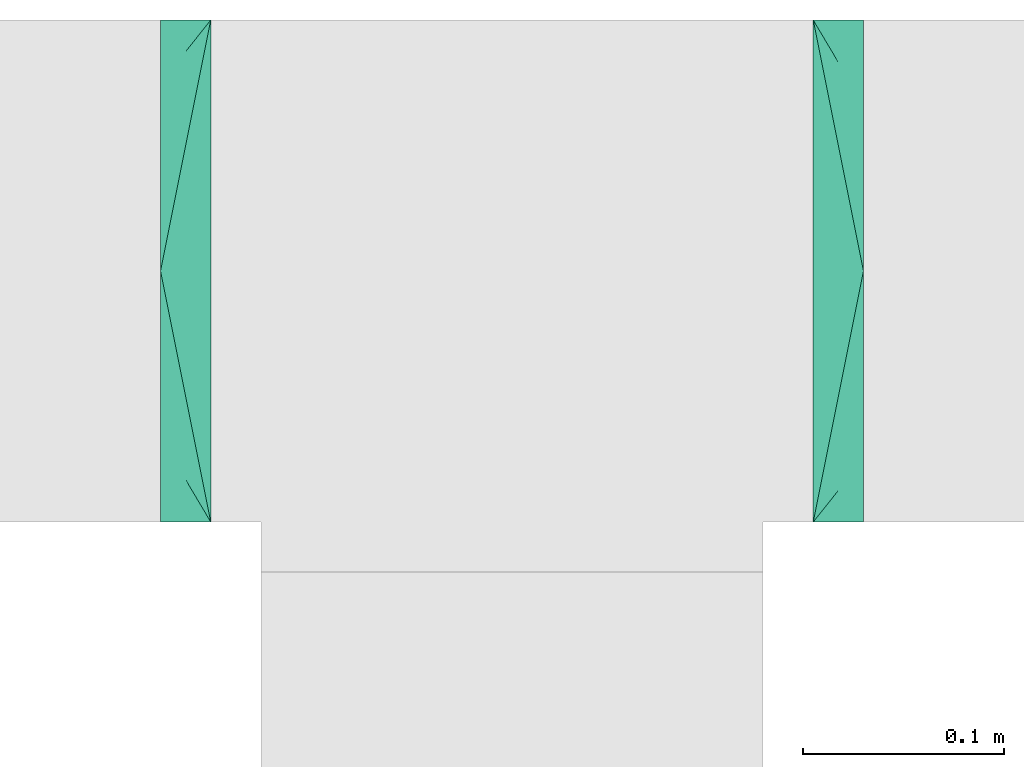
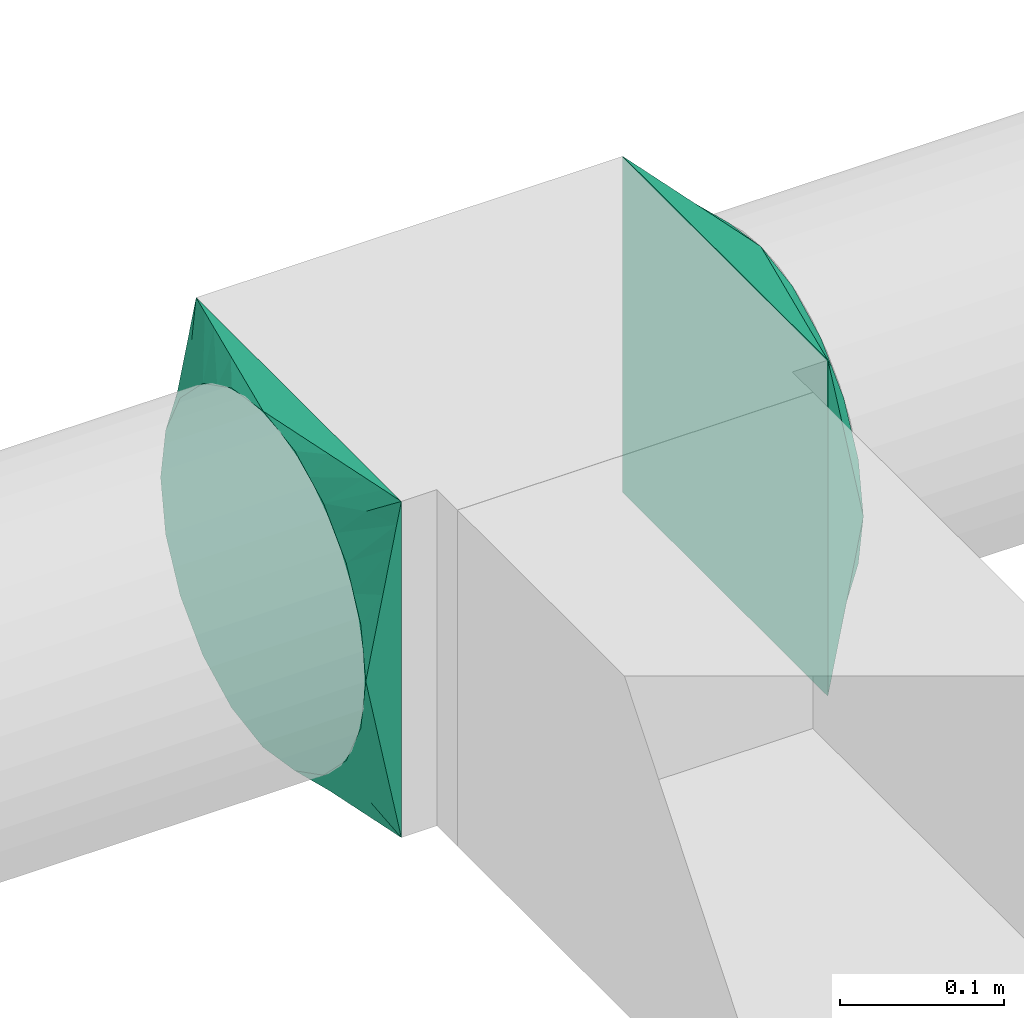
# One storey, part 2 of 3: 2 flow fittings.
"""IFC2X3 building model written with IfcOpenShell, lengths in millimetres."""

from ifc_helpers import new_model, entity, si_unit, converted_unit, derived_unit, direction, frame, origin, place, context, subcontext, project, spatial, faceted_brep, source, transform, mapped, material, type_object, type_shapes, element, save


model = new_model("IFC2X3")

# Units and contexts
model_context = context("Model", 3, precision=0.01, world=origin(), true_north=direction((6.12303176911189e-17, 1.0)))
body_context = subcontext(model_context, "Body", "Model", "MODEL_VIEW")
ifc_project = project(units=[si_unit("LENGTHUNIT", "METRE", prefix="MILLI"), si_unit("AREAUNIT", "SQUARE_METRE"), si_unit("VOLUMEUNIT", "CUBIC_METRE"), converted_unit("PLANEANGLEUNIT", "DEGREE", entity("IfcRatioMeasure", 0.0174532925199433), si_unit("PLANEANGLEUNIT", "RADIAN"), dimensions=[0, 0, 0, 0, 0, 0, 0]), si_unit("MASSUNIT", "GRAM", prefix="KILO"), derived_unit("MASSDENSITYUNIT", [(si_unit("MASSUNIT", "GRAM", prefix="KILO"), 1), (si_unit("LENGTHUNIT", "METRE"), -3)]), si_unit("TIMEUNIT", "SECOND"), si_unit("FREQUENCYUNIT", "HERTZ"), si_unit("THERMODYNAMICTEMPERATUREUNIT", "DEGREE_CELSIUS"), derived_unit("THERMALTRANSMITTANCEUNIT", [(si_unit("MASSUNIT", "GRAM", prefix="KILO"), 1), (si_unit("THERMODYNAMICTEMPERATUREUNIT", "KELVIN"), -1), (si_unit("TIMEUNIT", "SECOND"), -3)]), derived_unit("VOLUMETRICFLOWRATEUNIT", [(si_unit("LENGTHUNIT", "METRE"), 3), (si_unit("TIMEUNIT", "SECOND"), -1)]), si_unit("ELECTRICCURRENTUNIT", "AMPERE"), si_unit("ELECTRICVOLTAGEUNIT", "VOLT"), si_unit("POWERUNIT", "WATT"), si_unit("FORCEUNIT", "NEWTON", prefix="KILO"), si_unit("ILLUMINANCEUNIT", "LUX"), si_unit("LUMINOUSFLUXUNIT", "LUMEN"), si_unit("LUMINOUSINTENSITYUNIT", "CANDELA"), derived_unit("USERDEFINED", [(si_unit("MASSUNIT", "GRAM", prefix="KILO"), -1), (si_unit("LENGTHUNIT", "METRE"), -2), (si_unit("TIMEUNIT", "SECOND"), 3), (si_unit("LUMINOUSFLUXUNIT", "LUMEN"), 1)]), derived_unit("LINEARVELOCITYUNIT", [(si_unit("LENGTHUNIT", "METRE"), 1), (si_unit("TIMEUNIT", "SECOND"), -1)]), si_unit("PRESSUREUNIT", "PASCAL"), derived_unit("USERDEFINED", [(si_unit("LENGTHUNIT", "METRE"), -2), (si_unit("MASSUNIT", "GRAM", prefix="KILO"), 1), (si_unit("TIMEUNIT", "SECOND"), -2)])], contexts=[model_context])

# Site, building, storey
site_placement = place(None, origin())
site = spatial("IfcSite", under=ifc_project, at=site_placement, CompositionType="ELEMENT")
building_placement = place(site_placement, origin())
building = spatial("IfcBuilding", under=site, at=building_placement, CompositionType="ELEMENT")
storey_placement = place(building_placement, frame((0.0, 0.0, 8000.0)))
storey = spatial("IfcBuildingStorey", under=building, at=storey_placement, Name="02 Level", CompositionType="ELEMENT", Elevation=8000.0)

# Flow fittings
ifc_material = material(Name="Material_Duct")
duct_fitting_type = type_object("IfcDuctFittingType", Name="Air_Multi shape transition_Circ", PredefinedType="NOTDEFINED", material=ifc_material)
shared_shape = source(origin(), body_context, "Body", "Brep", [
    faceted_brep([(25.0, 38.627124296869, -118.882064536893), (25.0, 56.0501404167142, -110.00459441688), (25.0, 73.4731565365595, -101.127124296867), (25.0, 87.3001404167141, -87.3001404167125), (25.0, 101.127124296869, -73.4731565365578), (25.0, 110.004594416882, -56.0501404167124), (25.0, 118.882064536894, -38.6271242968671), (25.0, 121.223496625785, -23.8439038991246), (25.0, 123.111748312892, -11.9219519495616), (25.0, 124.055874156446, -5.96097597478013), (25.0, 125.0, 0.0), (25.0, 124.055874155635, 5.96097597990369), (25.0, 123.11174831127, 11.9219519598073), (25.0, 121.22349662254, 23.8439039196147), (25.0, 118.882064536894, 38.6271242968685), (25.0, 110.004594416881, 56.0501404167139), (25.0, 101.127124296868, 73.4731565365593), (25.0, 87.3001404167137, 87.3001404167139), (25.0, 73.473156536559, 101.127124296869), (25.0, 56.0501404167136, 110.004594416881), (25.0, 38.6271242968682, 118.882064536894), (25.0, 23.8439038991258, 121.223496625785), (25.0, 11.9219519495628, 123.111748312892), (25.0, 5.96097597478125, 124.055874156446), (25.0, 0.0, 125.0), (25.0, -5.96097597990388, 124.055874155635), (25.0, -11.9219519598075, 123.11174831127), (25.0, -23.8439039196148, 121.22349662254), (25.0, -38.6271242968687, 118.882064536894), (25.0, -56.050140416714, 110.004594416881), (25.0, -73.4731565365594, 101.127124296868), (25.0, -87.300140416714, 87.3001404167136), (25.0, -101.127124296869, 73.4731565365589), (25.0, -110.004594416881, 56.0501404167135), (25.0, -118.882064536894, 38.6271242968681), (25.0, -121.223496625785, 23.8439038991257), (25.0, -123.111748312893, 11.9219519495627), (25.0, -124.055874156446, 5.96097597478117), (25.0, -125.0, 0.0), (25.0, -124.055874155635, -5.96097597990274), (25.0, -123.11174831127, -11.9219519598064), (25.0, -121.22349662254, -23.8439039196137), (25.0, -118.882064536894, -38.6271242968675), (25.0, -110.004594416881, -56.0501404167129), (25.0, -101.127124296868, -73.4731565365583), (25.0, -87.3001404167137, -87.3001404167129), (25.0, -73.4731565365591, -101.127124296868), (25.0, -56.0501404167137, -110.00459441688), (25.0, -38.6271242968683, -118.882064536893), (25.0, -23.8439038991258, -121.223496625784), (25.0, -11.9219519495628, -123.111748312892), (25.0, -5.9609759747813, -124.055874156445), (25.0, 0.0, -125.0), (25.0, 5.96097597990422, -124.055874155634), (25.0, 11.9219519598079, -123.111748311269), (25.0, 23.8439039196152, -121.223496622539), (0.0, -125.0, -125.0), (0.0, -125.0, 125.0), (0.0, 125.0, 125.0), (0.0, 125.0, -125.0), (13.0142783389037, 59.9286083054818, 125.0), (3.25356958472593, 108.732152076371, 125.0), (12.4999999334883, 103.93826768006, 109.288032538106), (16.0107087541778, 44.9464562291113, 125.0), (19.0071391694519, 29.9643041527408, 125.0), (22.0035695847259, 14.9821520763703, 125.0), (23.501784792363, 7.49107603818503, 125.0), (6.50713897169544, 125.0, 92.464305141524), (3.25356948584772, 125.0, 108.732152570763), (9.76070845754316, 125.0, 76.1964577122852), (13.0142779433909, 125.0, 59.9286102830464), (23.5017847429239, 125.0, 7.49107628538083), (22.0035694858477, 125.0, 14.9821525707616), (19.0071389716954, 125.0, 29.9643051415232), (16.0107084575432, 125.0, 44.9464577122848), (6.50713916945185, 92.4643041527413, 125.0), (9.76070875417778, 76.1964562291116, 125.0), (23.501784792363, 125.0, -7.49107603818391), (22.0035695847259, 125.0, -14.9821520763692), (19.0071391694518, 125.0, -29.9643041527398), (16.0107087541778, 125.0, -44.9464562291103), (13.0142783389037, 125.0, -59.9286083054808), (9.76070875417777, 125.0, -76.1964562291106), (6.50713916945185, 125.0, -92.4643041527404), (3.25356958472592, 125.0, -108.73215207637), (12.4999999334883, 109.288032538106, -103.938267680059), (6.50713897169543, 92.4643051415237, -125.0), (3.25356948584772, 108.732152570762, -125.0), (9.76070845754315, 76.196457712285, -125.0), (13.0142779433909, 59.9286102830464, -125.0), (23.5017847429239, 7.49107628538129, -125.0), (22.0035694858477, 14.982152570762, -125.0), (19.0071389716954, 29.9643051415235, -125.0), (16.0107084575431, 44.9464577122849, -125.0), (23.501784792363, -7.49107603818498, -125.0), (22.0035695847259, -14.9821520763701, -125.0), (19.0071391694519, -29.9643041527404, -125.0), (16.0107087541778, -44.9464562291108, -125.0), (13.0142783389037, -59.9286083054811, -125.0), (9.76070875417778, -76.1964562291107, -125.0), (6.50713916945185, -92.4643041527402, -125.0), (3.25356958472593, -108.73215207637, -125.0), (12.4999999334883, -103.938267680059, -109.288032538105), (6.50713897169544, -125.0, -92.4643051415225), (3.25356948584772, -125.0, -108.732152570761), (9.76070845754316, -125.0, -76.1964577122838), (13.0142779433909, -125.0, -59.9286102830451), (23.5017847429239, -125.0, -7.49107628537984), (22.0035694858477, -125.0, -14.9821525707606), (19.0071389716954, -125.0, -29.9643051415221), (16.0107084575432, -125.0, -44.9464577122836), (23.501784792363, -125.0, 7.49107603818499), (22.0035695847259, -125.0, 14.9821520763703), (19.0071391694519, -125.0, 29.9643041527409), (16.0107087541778, -125.0, 44.9464562291115), (13.0142783389037, -125.0, 59.9286083054821), (9.76070875417777, -125.0, 76.196456229112), (6.50713916945185, -125.0, 92.4643041527418), (3.25356958472593, -125.0, 108.732152076372), (12.4999999334883, -109.288032538105, 103.93826768006), (6.50713897169544, -92.4643051415224, 125.0), (3.25356948584772, -108.732152570761, 125.0), (9.76070845754316, -76.1964577122839, 125.0), (13.0142779433909, -59.9286102830454, 125.0), (23.5017847429239, -7.49107628538088, 125.0), (22.0035694858477, -14.9821525707615, 125.0), (19.0071389716954, -29.9643051415228, 125.0), (16.0107084575432, -44.9464577122841, 125.0)], [[[0, 1, 2, 3, 4, 5, 6, 7, 8, 9, 10, 11, 12, 13, 14, 15, 16, 17, 18, 19, 20, 21, 22, 23, 24, 25, 26, 27, 28, 29, 30, 31, 32, 33, 34, 35, 36, 37, 38, 39, 40, 41, 42, 43, 44, 45, 46, 47, 48, 49, 50, 51, 52, 53, 54, 55]], [[56, 57, 58, 59]], [[20, 19, 60]], [[61, 62, 58]], [[60, 63, 64, 65, 66, 24, 23, 22, 21, 20]], [[67, 68, 16]], [[18, 62, 61]], [[69, 67, 15, 70]], [[13, 12, 11, 10, 71, 72, 73, 74, 70, 14]], [[19, 18, 75]], [[76, 60, 19, 75]], [[15, 14, 70]], [[17, 68, 62]], [[61, 75, 18]], [[17, 16, 68]], [[17, 62, 18]], [[68, 58, 62]], [[16, 15, 67]], [[77, 78, 79, 80, 81, 82, 83, 84, 59, 58, 68, 67, 69, 70, 74, 73, 72, 71, 10]], [[6, 5, 81]], [[84, 85, 59]], [[81, 80, 79, 78, 77, 10, 9, 8, 7, 6]], [[86, 87, 2]], [[4, 85, 84]], [[88, 86, 1, 89]], [[55, 54, 53, 52, 90, 91, 92, 93, 89, 0]], [[5, 4, 83]], [[82, 81, 5, 83]], [[1, 0, 89]], [[3, 87, 85]], [[84, 83, 4]], [[3, 2, 87]], [[3, 85, 4]], [[87, 59, 85]], [[2, 1, 86]], [[56, 59, 87, 86, 88, 89, 93, 92, 91, 90, 52, 94, 95, 96, 97, 98, 99, 100, 101]], [[48, 47, 98]], [[101, 102, 56]], [[98, 97, 96, 95, 94, 52, 51, 50, 49, 48]], [[103, 104, 44]], [[46, 102, 101]], [[105, 103, 43, 106]], [[41, 40, 39, 38, 107, 108, 109, 110, 106, 42]], [[47, 46, 100]], [[99, 98, 47, 100]], [[43, 42, 106]], [[45, 104, 102]], [[101, 100, 46]], [[45, 44, 104]], [[45, 102, 46]], [[104, 56, 102]], [[44, 43, 103]], [[111, 112, 113, 114, 115, 116, 117, 118, 57, 56, 104, 103, 105, 106, 110, 109, 108, 107, 38]], [[34, 33, 115]], [[118, 119, 57]], [[115, 114, 113, 112, 111, 38, 37, 36, 35, 34]], [[120, 121, 30]], [[32, 119, 118]], [[122, 120, 29, 123]], [[27, 26, 25, 24, 124, 125, 126, 127, 123, 28]], [[33, 32, 117]], [[116, 115, 33, 117]], [[29, 28, 123]], [[31, 121, 119]], [[118, 117, 32]], [[31, 30, 121]], [[31, 119, 32]], [[121, 57, 119]], [[30, 29, 120]], [[66, 65, 64, 63, 60, 76, 75, 61, 58, 57, 121, 120, 122, 123, 127, 126, 125, 124, 24]]]),
])
type_shapes(duct_fitting_type, [shared_shape])
flow_fitting_1_placement = place(storey_placement, frame((24480.6615179764, -63810.5772743263, 3510.0), z_axis=(0.0, 0.0, 1.0), x_axis=(-1.0, 0.0, 0.0)))
element("IfcFlowFitting", 1, at=flow_fitting_1_placement, inside=storey, type_object=duct_fitting_type, material=ifc_material, Name="multi_shape_trans_001:Air_Multi shape transition_Circ", ObjectType="multi_shape_trans_001:Air_Multi shape transition_Circ", context=body_context, shape_type="MappedRepresentation", body=[
    mapped(shared_shape, transform((0.0, 0.0, 0.0), scale=1.0)),
])
flow_fitting_2_placement = place(storey_placement, frame((24780.6615179764, -63810.5772743263, 3510.0)))
element("IfcFlowFitting", 2, at=flow_fitting_2_placement, inside=storey, type_object=duct_fitting_type, material=ifc_material, Name="multi_shape_trans_001:Air_Multi shape transition_Circ", ObjectType="multi_shape_trans_001:Air_Multi shape transition_Circ", context=body_context, shape_type="MappedRepresentation", body=[
    mapped(shared_shape, transform((0.0, 0.0, 0.0), scale=1.0)),
])

save(model, "model.ifc")
